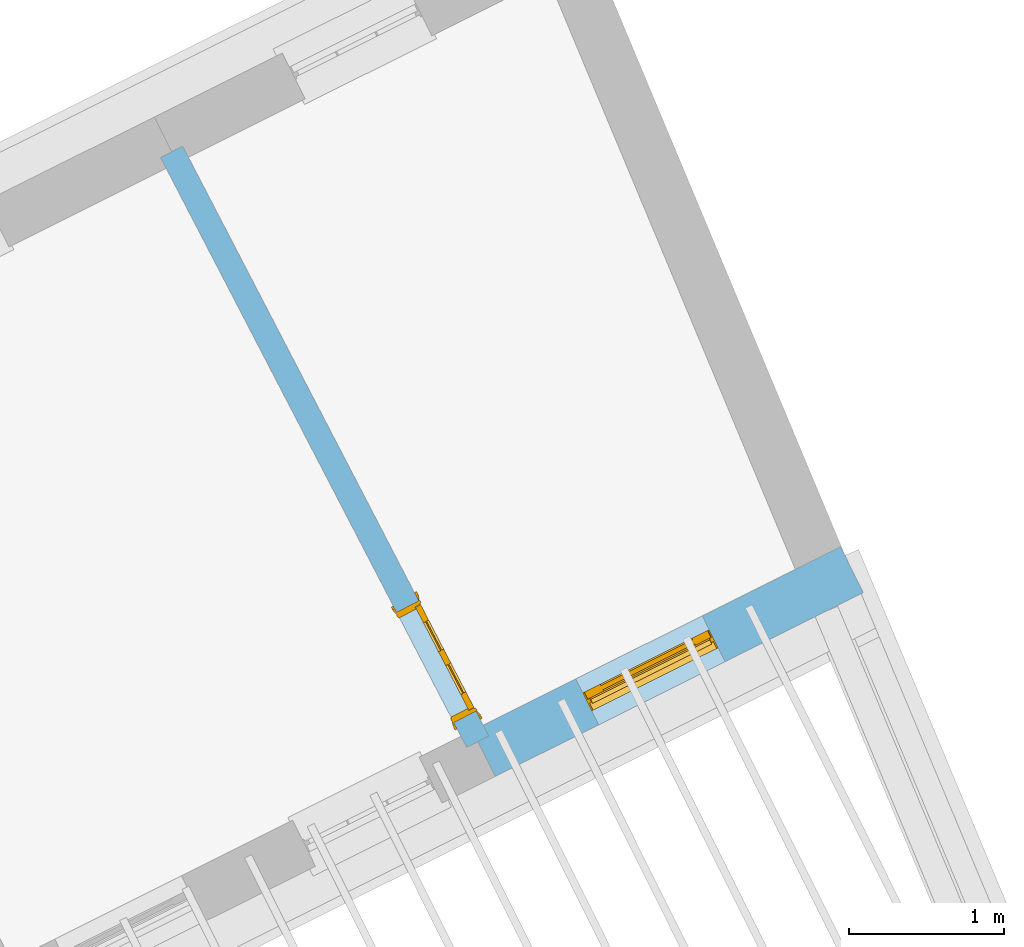
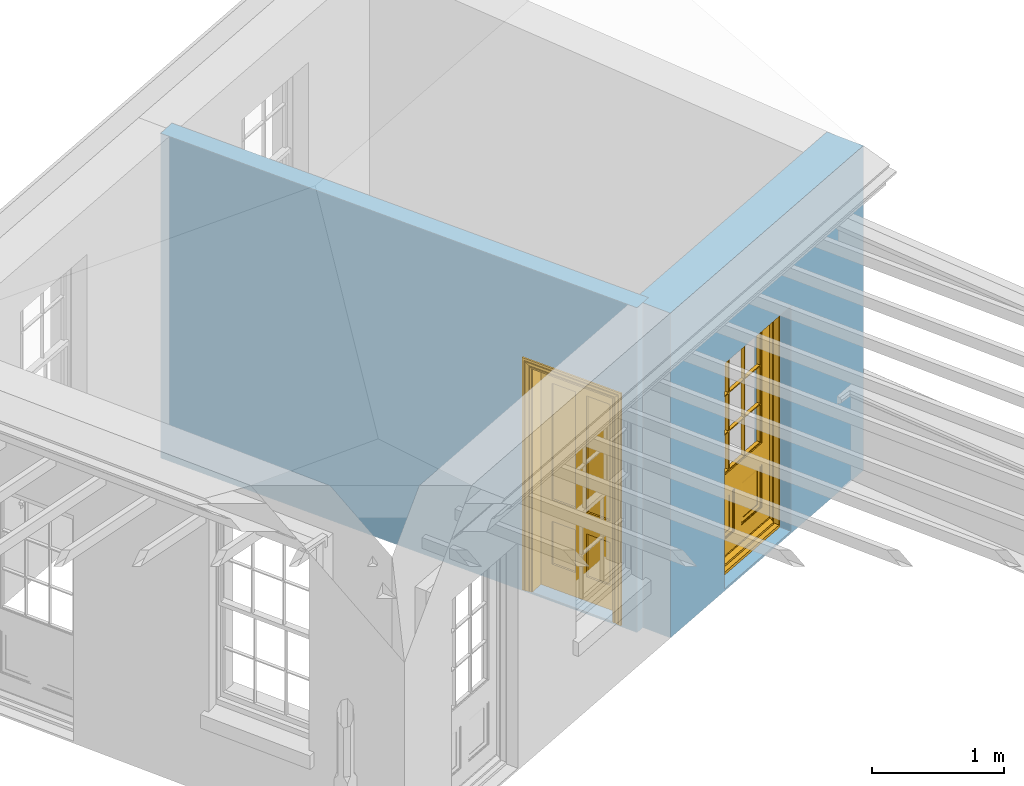
# One storey, part 4 of 7: 2 doors, 2 openings, plus 2 elements that do not belong to this part.
"""IFC2X3 building model written with IfcOpenShell, lengths in metres."""

from ifc_helpers import new_model, si_unit, frame, origin, place, context, subcontext, project, spatial, polyline, outline, extrude, faceted_brep, material, layer, layer_set, layer_usage, element, fill, save


model = new_model("IFC2X3")

# Units and contexts
model_context = context("Model", 3, world=origin())
body_context = subcontext(model_context, "Body", "Model", "MODEL_VIEW")
ifc_project = project(units=[si_unit("PLANEANGLEUNIT", "RADIAN"), si_unit("MASSUNIT", "GRAM", prefix="KILO"), si_unit("FORCEUNIT", "NEWTON", prefix="KILO"), si_unit("LENGTHUNIT", "METRE")], contexts=[model_context])

# Site, building, storey
site_placement = place(None, origin())
site = spatial("IfcSite", under=ifc_project, at=site_placement, CompositionType="ELEMENT")
building_placement = place(None, origin())
building = spatial("IfcBuilding", under=site, at=building_placement, Name="Building plot-8", CompositionType="ELEMENT")
storey_placement = place(None, frame((0.0, 0.0, 6.3)))
storey = spatial("IfcBuildingStorey", under=building, at=storey_placement, Name="Floor 2", CompositionType="ELEMENT", Elevation=6.3)

# Wall, opening, door
ifc_material_1 = material(Name="Masonry")
ifc_layer_1 = layer(ifc_material_1, 0.33, ventilated=False)
ifc_layer_set_1 = layer_set([ifc_layer_1], Name="My Wall")
ifc_layer_usage_1 = layer_usage(ifc_layer_set_1, "AXIS2", "NEGATIVE", 0.08)
wall_1_placement = place(storey_placement, origin())
wall_1 = element("IfcWallStandardCase", 1, at=wall_1_placement, inside=storey, material=ifc_layer_usage_1, Name="exterior", context=body_context, shape_type="SweptSolid", body=[
    extrude(outline(polyline([(27.4102456579562, 14.9420865634283), (27.5576474990724, 14.6468363352565), (29.9270645302191, 15.8297530595747), (29.7796626891029, 16.1250032877466), (27.4102456579562, 14.9420865634283)])), origin(), (0.0, 0.0, 1.0), 3.0),
])
opening_1_placement = place(storey_placement, frame((0.0, 0.0, 0.0199999999999996)))
opening_1 = element("IfcOpeningElement", 2, at=opening_1_placement, cuts=wall_1, Name="Opening", ObjectType="Opening", context=body_context, shape_type="SweptSolid", body=[
    extrude(outline(polyline([(28.2234313711922, 14.9792247948476), (29.0376062428176, 15.3856965385319), (28.8902044017014, 15.6809467667037), (28.0760295300759, 15.2744750230195), (28.2234313711922, 14.9792247948476)])), origin(), (0.0, 0.0, 1.0), 2.08),
])
door_1_placement = place(storey_placement, frame((28.1117633097405, 15.2028992101293, 0.0199999999999996), z_axis=(0.0, 0.0, 1.0), x_axis=(0.814174871625429, 0.406471743684248, 0.0)))
door_1 = element("IfcDoor", 3, at=door_1_placement, inside=storey, Name="bedroom outside door", OverallHeight=2.08, OverallWidth=0.91, context=body_context, shape_type="Brep", held_by="IfcProductRepresentation", body=[
    faceted_brep([(0.545, -0.055, 0.265), (0.745, -0.055, 0.265), (0.745, -0.05, 0.265), (0.545, -0.05, 0.265), (0.745, -0.05, 0.58), (0.545, -0.05, 0.58), (0.545, -0.055, 0.58), (0.515, -0.06, 0.235), (0.775, -0.06, 0.235), (0.745, -0.055, 0.58), (0.515, -0.06, 0.61), (0.515, -0.065, 0.235), (0.775, -0.065, 0.235), (0.775, -0.06, 0.61), (0.515, -0.065, 0.61), (0.785, -0.065, 0.225), (0.505, -0.065, 0.225), (0.775, -0.065, 0.61), (0.505, -0.065, 0.62), (0.785, -0.065, 0.62), (0.505, -0.07, 0.225), (0.785, -0.07, 0.225), (0.505, -0.07, 0.62), (0.785, -0.07, 0.62), (0.883, -0.07, 0.075), (0.898, -0.07, 0.075), (0.405, -0.07, 0.62), (0.405, -0.07, 0.225), (0.027, -0.07, 0.075), (0.785, -0.07, 0.82), (0.125, -0.07, 0.82), (0.405, -0.065, 0.62), (0.405, -0.065, 0.225), (0.898, -0.07, 2.068), (0.027, -0.08, 0.075), (0.883, -0.08, 0.075), (0.125, -0.07, 0.225), (0.012, -0.07, 0.075), (0.785, -0.06, 0.82), (0.125, -0.06, 0.82), (0.125, -0.07, 0.62), (0.125, -0.065, 0.62), (0.395, -0.065, 0.61), (0.395, -0.065, 0.235), (0.125, -0.065, 0.225), (0.785, -0.07, 1.895), (0.027, -0.11, 0.045), (0.883, -0.11, 0.045), (0.558333, -0.06, 0.83), (0.351667, -0.06, 0.83), (0.125, -0.07, 1.895), (0.125, -0.06, 1.895), (0.785, -0.06, 1.895), (0.012, -0.07, 2.068), (0.135, -0.065, 0.61), (0.395, -0.06, 0.61), (0.395, -0.06, 0.235), (0.135, -0.065, 0.235), (0.027, -0.11, 0.027), (0.883, -0.11, 0.027), (0.568333, -0.06, 0.83), (0.558333, -0.03, 0.83), (0.351667, -0.03, 0.83), (0.341667, -0.06, 0.83), (0.135, -0.06, 1.185), (0.135, -0.06, 1.53), (0.775, -0.06, 1.53), (0.775, -0.06, 1.185), (0.135, -0.06, 0.61), (0.365, -0.055, 0.58), (0.365, -0.055, 0.265), (0.135, -0.06, 0.235), (0.568333, -0.06, 1.175), (0.558333, -0.06, 1.175), (0.775, -0.06, 0.83), (0.558333, -0.03, 1.175), (0.785, -0.03, 0.82), (0.125, -0.03, 0.82), (0.351667, -0.03, 1.175), (0.351667, -0.06, 1.175), (0.341667, -0.06, 1.175), (0.135, -0.06, 0.83), (0.135, -0.06, 1.175), (0.135, -0.03, 1.185), (0.135, -0.03, 1.53), (0.135, -0.06, 1.54), (0.351667, -0.06, 1.885), (0.558333, -0.06, 1.885), (0.775, -0.03, 1.53), (0.775, -0.03, 1.185), (0.775, -0.06, 1.175), (0.775, -0.06, 1.54), (0.165, -0.055, 0.58), (0.365, -0.05, 0.58), (0.365, -0.05, 0.265), (0.165, -0.055, 0.265), (0.568333, -0.03, 0.83), (0.568333, -0.03, 1.175), (0.568333, -0.06, 1.185), (0.558333, -0.06, 1.185), (0.775, -0.03, 0.83), (0.785, -0.02, 0.82), (0.125, -0.02, 0.82), (0.341667, -0.03, 0.83), (0.341667, -0.03, 1.175), (0.351667, -0.06, 1.185), (0.341667, -0.06, 1.185), (0.135, -0.03, 0.83), (0.341667, -0.03, 1.185), (0.125, -0.03, 1.895), (0.341667, -0.03, 1.53), (0.341667, -0.06, 1.53), (0.135, -0.06, 1.885), (0.341667, -0.06, 1.54), (0.341667, -0.06, 1.885), (0.558333, -0.03, 1.885), (0.351667, -0.03, 1.885), (0.568333, -0.06, 1.885), (0.785, -0.03, 1.895), (0.568333, -0.03, 1.185), (0.568333, -0.06, 1.53), (0.568333, -0.03, 1.53), (0.568333, -0.06, 1.54), (0.775, -0.06, 1.885), (0.165, -0.05, 0.58), (0.165, -0.05, 0.265), (0.775, -0.03, 1.175), (0.558333, -0.06, 1.53), (0.351667, -0.03, 1.185), (0.558333, -0.03, 1.185), (0.505, -0.02, 0.62), (0.405, -0.02, 0.62), (0.125, -0.02, 1.895), (0.785, -0.02, 1.895), (0.351667, -0.06, 1.53), (0.135, -0.03, 1.175), (0.135, -0.03, 1.54), (0.341667, -0.03, 1.54), (0.135, -0.03, 1.885), (0.351667, -0.06, 1.54), (0.558333, -0.03, 1.54), (0.558333, -0.06, 1.54), (0.351667, -0.03, 1.54), (0.775, -0.03, 1.54), (0.568333, -0.03, 1.54), (0.775, -0.03, 1.885), (0.558333, -0.03, 1.53), (0.405, -0.02, 0.225), (0.505, -0.02, 0.225), (0.125, -0.02, 0.62), (0.785, -0.02, 0.62), (0.012, -0.02, 2.068), (0.898, -0.02, 2.068), (0.351667, -0.03, 1.53), (0.341667, -0.03, 1.885), (0.568333, -0.03, 1.885), (0.405, -0.025, 0.225), (0.405, -0.025, 0.62), (0.505, -0.025, 0.62), (0.505, -0.025, 0.225), (0.898, -0.02, 0.027), (0.012, -0.02, 0.027), (0.125, -0.025, 0.62), (0.785, -0.025, 0.62), (0.395, -0.025, 0.235), (0.395, -0.025, 0.61), (0.125, -0.02, 0.225), (0.125, -0.025, 0.225), (0.515, -0.025, 0.61), (0.515, -0.025, 0.235), (0.785, -0.02, 0.225), (0.785, -0.025, 0.225), (0.135, -0.025, 0.61), (0.775, -0.025, 0.61), (0.135, -0.025, 0.235), (0.395, -0.03, 0.235), (0.395, -0.03, 0.61), (0.515, -0.03, 0.61), (0.515, -0.03, 0.235), (0.775, -0.025, 0.235), (0.135, -0.03, 0.61), (0.775, -0.03, 0.61), (0.135, -0.03, 0.235), (0.365, -0.035, 0.265), (0.365, -0.035, 0.58), (0.545, -0.035, 0.58), (0.545, -0.035, 0.265), (0.775, -0.03, 0.235), (0.165, -0.035, 0.58), (0.745, -0.035, 0.58), (0.165, -0.035, 0.265), (0.365, -0.04, 0.58), (0.365, -0.04, 0.265), (0.545, -0.04, 0.58), (0.545, -0.04, 0.265), (0.745, -0.035, 0.265), (0.165, -0.04, 0.58), (0.745, -0.04, 0.58), (0.165, -0.04, 0.265), (0.745, -0.04, 0.265), (0.885, -0.072, 0.025), (0.025, -0.072, 0.025), (0.025, -0.1, 0.025), (0.885, -0.1, 0.025), (0.9, -0.02, 0.025), (0.01, -0.02, 0.025), (0.9, -0.072, 0.025), (0.91, -0.02, 0.0), (0.0, -0.02, 0.0), (0.01, -0.072, 0.025), (0.9, -0.072, 2.07), (0.9, -0.02, 2.07), (0.885, -0.072, 2.055), (0.91, -0.02, 2.08), (0.01, -0.02, 2.07), (0.0, -0.02, 2.08), (0.01, -0.072, 2.07), (0.025, -0.072, 2.055), (0.0, -0.15, 2.08), (0.91, -0.15, 2.08), (0.01, -0.15, 2.07), (0.9, -0.15, 2.07), (0.01, -0.1, 2.07), (0.9, -0.1, 2.07), (0.0, -0.15, 0.0), (0.91, -0.15, 0.0), (0.01, -0.15, 0.025), (0.9, -0.15, 0.025), (0.01, -0.1, 0.025), (0.025, -0.1, 2.055), (0.9, -0.1, 0.025), (0.885, -0.1, 2.055), (0.898, -0.07, 0.027), (0.012, -0.07, 0.027), (0.883, -0.07, 0.027), (0.027, -0.07, 0.027)], [[[0, 1, 2, 3]], [[2, 4, 5, 3]], [[0, 3, 5, 6]], [[1, 0, 7, 8]], [[9, 4, 2, 1]], [[9, 6, 5, 4]], [[0, 6, 10, 7]], [[8, 7, 11, 12]], [[8, 13, 9, 1]], [[13, 10, 6, 9]], [[7, 10, 14, 11]], [[15, 12, 11, 16]], [[12, 17, 13, 8]], [[17, 14, 10, 13]], [[18, 16, 11, 14]], [[15, 19, 17, 12]], [[15, 16, 20, 21]], [[14, 17, 19, 18]], [[16, 18, 22, 20]], [[21, 23, 19, 15]], [[24, 25, 21, 20]], [[23, 22, 18, 19]], [[20, 22, 26, 27]], [[23, 21, 25]], [[28, 24, 20, 27]], [[22, 23, 29]], [[29, 30, 26, 22]], [[27, 26, 31, 32]], [[23, 25, 33, 29]], [[34, 35, 24, 28]], [[28, 27, 36, 37]], [[38, 39, 30, 29]], [[26, 30, 40]], [[26, 40, 41, 31]], [[42, 43, 32, 31]], [[32, 44, 36, 27]], [[33, 45, 29]], [[46, 47, 35, 34]], [[36, 40, 37]], [[39, 38, 48, 49]], [[50, 30, 39, 51]], [[29, 45, 52, 38]], [[53, 37, 40, 30]], [[44, 41, 40, 36]], [[31, 41, 54, 42]], [[43, 42, 55, 56]], [[57, 44, 32, 43]], [[50, 45, 33, 53]], [[47, 46, 58, 59]], [[60, 48, 38]], [[49, 48, 61, 62]], [[49, 63, 39]], [[50, 53, 30]], [[51, 39, 64, 65]], [[45, 50, 51, 52]], [[66, 67, 38, 52]], [[57, 54, 41, 44]], [[42, 54, 68, 55]], [[56, 55, 69, 70]], [[56, 71, 57, 43]], [[60, 72, 73, 48]], [[60, 38, 74]], [[48, 73, 75, 61]], [[76, 77, 62, 61]], [[62, 78, 79, 49]], [[49, 79, 80, 63]], [[63, 81, 39]], [[82, 64, 39]], [[65, 64, 83, 84]], [[85, 51, 65]], [[52, 51, 86, 87]], [[88, 89, 67, 66]], [[90, 38, 67]], [[91, 66, 52]], [[71, 68, 54, 57]], [[55, 68, 92, 69]], [[69, 93, 94, 70]], [[70, 95, 71, 56]], [[96, 97, 72, 60]], [[73, 72, 98, 99]], [[74, 38, 90]], [[100, 96, 60, 74]], [[75, 73, 79, 78]], [[61, 75, 97, 96]], [[101, 102, 77, 76]], [[77, 103, 62]], [[96, 76, 61]], [[103, 104, 78, 62]], [[80, 79, 105, 106]], [[63, 80, 104, 103]], [[81, 63, 103, 107]], [[81, 82, 39]], [[106, 64, 82, 80]], [[106, 108, 83, 64]], [[84, 83, 77, 109]], [[110, 111, 65, 84]], [[112, 51, 85]], [[113, 85, 65, 111]], [[114, 86, 51]], [[115, 87, 86, 116]], [[117, 52, 87]], [[118, 76, 89, 88]], [[119, 98, 67, 89]], [[120, 121, 88, 66]], [[67, 98, 72, 90]], [[91, 122, 120, 66]], [[91, 52, 123]], [[95, 92, 68, 71]], [[69, 92, 124, 93]], [[94, 93, 124, 125]], [[94, 125, 95, 70]], [[72, 97, 126, 90]], [[127, 99, 98, 120]], [[99, 105, 79, 73]], [[74, 90, 126, 100]], [[96, 100, 76]], [[128, 129, 75, 78]], [[97, 75, 129, 119]], [[130, 131, 102, 101]], [[109, 77, 102, 132]], [[133, 101, 76, 118]], [[77, 107, 103]], [[78, 104, 108, 128]], [[111, 106, 105, 134]], [[104, 80, 82, 135]], [[107, 135, 82, 81]], [[110, 108, 106, 111]], [[104, 135, 83, 108]], [[83, 135, 77]], [[136, 84, 109]], [[110, 84, 136, 137]], [[114, 51, 112]], [[85, 136, 138, 112]], [[113, 137, 136, 85]], [[111, 134, 139, 113]], [[86, 114, 113, 139]], [[140, 141, 87, 115]], [[139, 142, 116, 86]], [[109, 118, 115, 116]], [[117, 123, 52]], [[117, 87, 141, 122]], [[126, 89, 76]], [[143, 118, 88]], [[120, 98, 119, 121]], [[119, 89, 126, 97]], [[144, 143, 88, 121]], [[144, 122, 91, 143]], [[127, 120, 122, 141]], [[143, 91, 123, 145]], [[124, 92, 95, 125]], [[146, 129, 99, 127]], [[99, 129, 128, 105]], [[100, 126, 76]], [[121, 119, 129, 146]], [[147, 131, 130, 148]], [[131, 149, 102]], [[130, 101, 150]], [[102, 151, 132]], [[118, 109, 132, 133]], [[101, 133, 152]], [[107, 77, 135]], [[153, 128, 108, 110]], [[134, 105, 128, 153]], [[109, 138, 136]], [[153, 110, 137, 142]], [[154, 114, 112, 138]], [[137, 113, 114, 154]], [[141, 139, 134, 127]], [[141, 140, 142, 139]], [[144, 140, 115, 155]], [[142, 137, 154, 116]], [[155, 115, 118]], [[116, 154, 109]], [[117, 155, 145, 123]], [[122, 144, 155, 117]], [[143, 145, 118]], [[121, 146, 140, 144]], [[146, 127, 134, 153]], [[156, 157, 131, 147]], [[148, 130, 158, 159]], [[148, 160, 161, 147]], [[157, 162, 149, 131]], [[161, 151, 102, 149]], [[101, 152, 160, 150]], [[163, 158, 130, 150]], [[151, 152, 133, 132]], [[154, 138, 109]], [[142, 140, 146, 153]], [[145, 155, 118]], [[157, 156, 164, 165]], [[147, 166, 167, 156]], [[168, 169, 159, 158]], [[170, 148, 159, 171]], [[148, 170, 160]], [[166, 147, 161]], [[172, 162, 157, 165]], [[166, 149, 162, 167]], [[166, 161, 149]], [[150, 160, 170]], [[163, 173, 168, 158]], [[171, 163, 150, 170]], [[174, 164, 156, 167]], [[175, 176, 165, 164]], [[169, 168, 177, 178]], [[171, 159, 169, 179]], [[167, 162, 172, 174]], [[176, 180, 172, 165]], [[179, 173, 163, 171]], [[181, 177, 168, 173]], [[164, 174, 182, 175]], [[183, 184, 176, 175]], [[178, 177, 185, 186]], [[179, 169, 178, 187]], [[174, 172, 180, 182]], [[184, 188, 180, 176]], [[187, 181, 173, 179]], [[189, 185, 177, 181]], [[175, 182, 190, 183]], [[191, 184, 183, 192]], [[185, 193, 194, 186]], [[187, 178, 186, 195]], [[182, 180, 188, 190]], [[191, 196, 188, 184]], [[195, 189, 181, 187]], [[197, 193, 185, 189]], [[183, 190, 198, 192]], [[198, 196, 191, 192]], [[194, 193, 197, 199]], [[195, 186, 194, 199]], [[188, 196, 198, 190]], [[197, 189, 195, 199]], [[200, 201, 202, 203]], [[201, 200, 204, 205]], [[206, 204, 200]], [[204, 207, 208, 205]], [[209, 201, 205]], [[210, 211, 204, 206]], [[206, 200, 212, 210]], [[211, 213, 207, 204]], [[214, 205, 208, 215]], [[216, 217, 201, 209]], [[205, 214, 216, 209]], [[216, 214, 211, 210]], [[210, 212, 217, 216]], [[214, 215, 213, 211]], [[218, 219, 213, 215]], [[219, 218, 220, 221]], [[221, 220, 222, 223]], [[215, 208, 224, 218]], [[225, 224, 208, 207]], [[224, 226, 220, 218]], [[224, 225, 227, 226]], [[219, 225, 207, 213]], [[228, 222, 220, 226]], [[219, 221, 227, 225]], [[226, 227, 203, 202]], [[202, 229, 222, 228]], [[228, 226, 202]], [[227, 221, 223, 230]], [[230, 203, 227]], [[217, 229, 202, 201]], [[231, 223, 222, 229]], [[230, 223, 231, 203]], [[231, 229, 217, 212]], [[212, 200, 203, 231]], [[33, 152, 151, 53]], [[25, 160, 152, 33]], [[161, 37, 53, 151]], [[232, 160, 25]], [[161, 233, 37]], [[160, 232, 234]], [[24, 234, 232, 25]], [[233, 161, 235]], [[37, 233, 235, 28]], [[161, 160, 234, 235]], [[35, 47, 234, 24]], [[28, 235, 46, 34]], [[58, 235, 234, 59]], [[59, 234, 47]], [[58, 46, 235]]]),
])
fill(opening_1, door_1)

ifc_material_2 = material(Name="Masonry")
ifc_layer_2 = layer(ifc_material_2, 0.16, ventilated=False)
ifc_layer_set_2 = layer_set([ifc_layer_2], Name="My Wall")
ifc_layer_usage_2 = layer_usage(ifc_layer_set_2, "AXIS2", "NEGATIVE", 0.08)
wall_2_placement = place(storey_placement, origin())
wall_2 = element("IfcWallStandardCase", 4, at=wall_2_placement, inside=storey, material=ifc_layer_usage_2, Name="interior", context=body_context, shape_type="SweptSolid", body=[
    extrude(outline(polyline([(25.5470428086069, 18.7028747535873), (25.4050311441155, 18.6291679889833), (27.374973605375, 14.8336573682362), (27.5169852698664, 14.9073641328402), (25.5470428086069, 18.7028747535873)])), origin(), (0.0, 0.0, 1.0), 3.0),
])
opening_2_placement = place(storey_placement, frame((0.0, 0.0, 0.0199999999999996)))
opening_2 = element("IfcOpeningElement", 5, at=opening_2_placement, cuts=wall_2, Name="Opening", ObjectType="Opening", context=body_context, shape_type="SweptSolid", body=[
    extrude(outline(polyline([(26.9235196721751, 15.7034788132456), (27.2920534951955, 14.9934204907889), (27.4340651596868, 15.067127255393), (27.0655313366665, 15.7771855778497), (26.9235196721751, 15.7034788132456)])), origin(), (0.0, 0.0, 1.0), 2.1),
])
door_2_placement = place(storey_placement, frame((26.9945255044208, 15.7403321955477, 0.0199999999999996), z_axis=(0.0, 0.0, 1.0), x_axis=(0.368533823020318, -0.710058322456703, 0.0)))
door_2 = element("IfcDoor", 6, at=door_2_placement, inside=storey, Name="bedroom inside door", OverallHeight=2.1, OverallWidth=0.8, context=body_context, shape_type="Brep", held_by="IfcProductRepresentation", body=[
    faceted_brep([(0.773, 0.08, 1.895), (0.66, 0.08, 1.895), (0.66, 0.08, 2.073), (0.773, 0.08, 2.073), (0.773, 0.08, 0.82), (0.66, 0.08, 0.82), (0.45, 0.08, 1.895), (0.45, 0.08, 2.073), (0.773, 0.08, 0.62), (0.66, 0.08, 0.62), (0.66, 0.065, 0.82), (0.66, 0.065, 1.895), (0.45, 0.065, 1.895), (0.35, 0.08, 1.895), (0.35, 0.08, 2.073), (0.773, 0.08, 0.225), (0.66, 0.08, 0.225), (0.45, 0.08, 0.62), (0.45, 0.08, 0.82), (0.45, 0.065, 0.82), (0.35, 0.08, 0.82), (0.14, 0.08, 2.073), (0.14, 0.08, 1.895), (0.773, 0.08, 0.0), (0.66, 0.08, 0.0), (0.66, 0.065, 0.225), (0.66, 0.065, 0.62), (0.45, 0.065, 0.62), (0.35, 0.08, 0.62), (0.35, 0.065, 0.82), (0.35, 0.065, 1.895), (0.14, 0.065, 1.895), (0.027, 0.08, 2.073), (0.027, 0.08, 1.895), (0.773, 0.042, 0.0), (0.66, 0.042, 0.0), (0.45, 0.08, 0.0), (0.45, 0.08, 0.225), (0.45, 0.065, 0.225), (0.35, 0.08, 0.225), (0.14, 0.08, 0.82), (0.14, 0.08, 0.62), (0.14, 0.065, 0.82), (0.027, 0.08, 0.82), (0.773, 0.042, 0.225), (0.66, 0.042, 0.225), (0.45, 0.042, 0.0), (0.35, 0.08, 0.0), (0.35, 0.065, 0.225), (0.35, 0.065, 0.62), (0.14, 0.065, 0.62), (0.027, 0.08, 0.62), (0.773, 0.042, 0.62), (0.66, 0.042, 0.62), (0.45, 0.042, 0.225), (0.35, 0.042, 0.0), (0.14, 0.08, 0.225), (0.14, 0.08, 0.0), (0.14, 0.065, 0.225), (0.027, 0.08, 0.225), (0.773, 0.042, 0.82), (0.66, 0.042, 0.82), (0.66, 0.057, 0.62), (0.66, 0.057, 0.225), (0.45, 0.057, 0.225), (0.35, 0.042, 0.225), (0.14, 0.042, 0.0), (0.027, 0.08, 0.0), (0.773, 0.042, 1.895), (0.66, 0.042, 1.895), (0.45, 0.042, 0.62), (0.45, 0.042, 0.82), (0.45, 0.057, 0.62), (0.35, 0.042, 0.62), (0.14, 0.042, 0.225), (0.027, 0.042, 0.0), (0.773, 0.042, 2.073), (0.66, 0.042, 2.073), (0.66, 0.057, 1.895), (0.66, 0.057, 0.82), (0.45, 0.057, 0.82), (0.35, 0.042, 0.82), (0.35, 0.057, 0.62), (0.35, 0.057, 0.225), (0.14, 0.057, 0.225), (0.027, 0.042, 0.225), (0.45, 0.042, 1.895), (0.45, 0.042, 2.073), (0.45, 0.057, 1.895), (0.35, 0.042, 1.895), (0.14, 0.042, 0.82), (0.14, 0.042, 0.62), (0.14, 0.057, 0.62), (0.027, 0.042, 0.62), (0.35, 0.042, 2.073), (0.35, 0.057, 1.895), (0.35, 0.057, 0.82), (0.14, 0.057, 0.82), (0.027, 0.042, 0.82), (0.14, 0.042, 2.073), (0.14, 0.042, 1.895), (0.14, 0.057, 1.895), (0.027, 0.042, 1.895), (0.027, 0.042, 2.073), (0.02, 0.085, 0.0), (0.005, 0.09, 0.0), (0.005, 0.09, 2.095), (0.02, 0.085, 2.08), (0.02, 0.08, 0.0), (0.0, 0.085, 0.0), (0.0, 0.085, 2.1), (0.795, 0.09, 2.095), (0.78, 0.085, 2.08), (0.02, 0.08, 2.08), (0.0, 0.08, 0.0), (-0.032, 0.095, 0.0), (-0.032, 0.095, 2.132), (0.8, 0.085, 2.1), (0.795, 0.09, 0.0), (0.78, 0.085, 0.0), (0.78, 0.08, 2.08), (0.04, 0.04, 0.0), (0.025, 0.04, 0.0), (0.025, 0.04, 2.075), (0.04, 0.04, 2.06), (-0.04, 0.09, 0.0), (-0.04, 0.09, 2.14), (0.832, 0.095, 2.132), (0.8, 0.085, 0.0), (0.78, 0.08, 0.0), (0.8, 0.08, 0.0), (0.86, 0.08, 0.0), (0.86, 0.08, 2.16), (0.8, 0.08, 2.1), (-0.06, 0.08, 2.16), (0.0, 0.08, 2.1), (-0.06, 0.08, 0.0), (-0.04, 0.095, 0.0), (-0.04, 0.095, 2.14), (0.84, 0.09, 2.14), (0.832, 0.095, 0.0), (0.84, 0.09, 0.0), (0.86, 0.095, 0.0), (0.86, 0.095, 2.16), (-0.06, 0.095, 2.16), (-0.06, 0.095, 0.0), (0.84, 0.095, 0.0), (0.84, 0.095, 2.14), (-0.025, -0.095, 0.0), (-0.025, -0.09, 0.0), (-0.025, -0.09, 2.125), (-0.025, -0.095, 2.125), (-0.017, -0.095, 0.0), (-0.017, -0.095, 2.117), (0.825, -0.09, 2.125), (0.825, -0.095, 2.125), (0.825, -0.095, 0.0), (0.845, -0.095, 0.0), (-0.045, -0.095, 2.145), (-0.045, -0.095, 0.0), (0.845, -0.095, 2.145), (0.015, -0.085, 0.0), (0.015, -0.085, 2.085), (0.817, -0.095, 2.117), (0.825, -0.09, 0.0), (0.845, -0.08, 0.0), (0.845, -0.08, 2.145), (-0.045, -0.08, 2.145), (-0.045, -0.08, 0.0), (0.02, -0.09, 0.0), (0.02, -0.09, 2.08), (0.785, -0.085, 2.085), (0.817, -0.095, 0.0), (0.8, -0.08, 0.0), (0.8, -0.08, 2.1), (0.0, -0.08, 2.1), (0.0, -0.08, 0.0), (0.035, -0.085, 0.0), (0.035, -0.085, 2.065), (0.78, -0.09, 2.08), (0.785, -0.085, 0.0), (0.775, 0.04, 2.075), (0.76, 0.04, 2.06), (0.035, -0.08, 2.065), (0.035, -0.08, 0.0), (0.765, -0.085, 2.065), (0.78, -0.09, 0.0), (0.765, -0.08, 0.0), (0.765, -0.08, 2.065), (0.765, -0.085, 0.0), (0.04, -0.08, 2.06), (0.04, -0.08, 0.0), (0.76, -0.08, 2.06), (0.76, -0.08, 0.0), (0.76, 0.04, 0.0), (0.775, 0.04, 0.0), (0.025, 0.08, 0.0), (0.025, 0.08, 2.075), (0.775, 0.08, 0.0), (0.775, 0.08, 2.075)], [[[0, 1, 2, 3]], [[1, 0, 4, 5]], [[1, 6, 7, 2]], [[8, 9, 5, 4]], [[1, 5, 10, 11]], [[6, 1, 11, 12]], [[6, 13, 14, 7]], [[15, 16, 9, 8]], [[9, 17, 18, 5]], [[5, 18, 19, 10]], [[10, 19, 12, 11]], [[18, 6, 12, 19]], [[18, 20, 13, 6]], [[21, 14, 13, 22]], [[23, 24, 16, 15]], [[9, 16, 25, 26]], [[17, 9, 26, 27]], [[17, 28, 20, 18]], [[13, 20, 29, 30]], [[22, 13, 30, 31]], [[32, 21, 22, 33]], [[34, 35, 24, 23]], [[24, 36, 37, 16]], [[16, 37, 38, 25]], [[25, 38, 27, 26]], [[37, 17, 27, 38]], [[37, 39, 28, 17]], [[40, 20, 28, 41]], [[20, 40, 42, 29]], [[31, 30, 29, 42]], [[40, 22, 31, 42]], [[33, 22, 40, 43]], [[35, 34, 44, 45]], [[35, 46, 36, 24]], [[36, 47, 39, 37]], [[28, 39, 48, 49]], [[41, 28, 49, 50]], [[43, 40, 41, 51]], [[45, 44, 52, 53]], [[46, 35, 45, 54]], [[46, 55, 47, 36]], [[56, 39, 47, 57]], [[39, 56, 58, 48]], [[50, 49, 48, 58]], [[56, 41, 50, 58]], [[51, 41, 56, 59]], [[53, 52, 60, 61]], [[45, 53, 62, 63]], [[54, 45, 63, 64]], [[55, 46, 54, 65]], [[55, 66, 57, 47]], [[59, 56, 57, 67]], [[61, 60, 68, 69]], [[70, 53, 61, 71]], [[53, 70, 72, 62]], [[72, 64, 63, 62]], [[70, 54, 64, 72]], [[65, 54, 70, 73]], [[65, 74, 66, 55]], [[67, 57, 66, 75]], [[69, 68, 76, 77]], [[61, 69, 78, 79]], [[71, 61, 79, 80]], [[73, 70, 71, 81]], [[65, 73, 82, 83]], [[74, 65, 83, 84]], [[74, 85, 75, 66]], [[86, 69, 77, 87]], [[69, 86, 88, 78]], [[88, 80, 79, 78]], [[86, 71, 80, 88]], [[81, 71, 86, 89]], [[73, 81, 90, 91]], [[73, 91, 92, 82]], [[83, 82, 92, 84]], [[91, 74, 84, 92]], [[91, 93, 85, 74]], [[89, 86, 87, 94]], [[81, 89, 95, 96]], [[90, 81, 96, 97]], [[90, 98, 93, 91]], [[94, 99, 100, 89]], [[89, 100, 101, 95]], [[101, 97, 96, 95]], [[100, 90, 97, 101]], [[100, 102, 98, 90]], [[99, 103, 102, 100]], [[32, 103, 99, 21]], [[102, 103, 32, 33]], [[98, 102, 33, 43]], [[21, 99, 94, 14]], [[94, 87, 7, 14]], [[7, 87, 77, 2]], [[76, 3, 2, 77]], [[43, 51, 93, 98]], [[51, 59, 85, 93]], [[67, 75, 85, 59]], [[34, 23, 15, 44]], [[44, 15, 8, 52]], [[52, 8, 4, 60]], [[0, 68, 60, 4]], [[0, 3, 76, 68]], [[104, 105, 106, 107]], [[104, 108, 109, 105]], [[105, 109, 110, 106]], [[107, 106, 111, 112]], [[107, 113, 108, 104]], [[114, 109, 108]], [[109, 115, 116, 110]], [[106, 110, 117, 111]], [[112, 111, 118, 119]], [[113, 107, 112, 120]], [[121, 122, 123, 124]], [[115, 109, 114, 125]], [[115, 125, 126, 116]], [[110, 116, 127, 117]], [[111, 117, 128, 118]], [[118, 128, 129, 119]], [[120, 112, 119, 129]], [[130, 129, 128]], [[130, 131, 132, 133]], [[133, 132, 134, 135]], [[135, 134, 136, 114]], [[136, 125, 114]], [[125, 137, 138, 126]], [[116, 126, 139, 127]], [[117, 127, 140, 128]], [[141, 130, 128, 140]], [[131, 130, 141]], [[131, 142, 143, 132]], [[132, 143, 144, 134]], [[134, 144, 145, 136]], [[137, 125, 136, 145]], [[143, 142, 146]], [[143, 146, 147]], [[137, 145, 144]], [[143, 147, 138]], [[138, 137, 144]], [[143, 138, 144]], [[126, 138, 147, 139]], [[127, 139, 141, 140]], [[142, 131, 141, 146]], [[139, 147, 146, 141]], [[148, 149, 150, 151]], [[149, 152, 153, 150]], [[151, 150, 154, 155]], [[155, 156, 157]], [[158, 159, 148]], [[158, 148, 151]], [[155, 157, 160]], [[158, 151, 155]], [[155, 160, 158]], [[152, 161, 162, 153]], [[150, 153, 163, 154]], [[155, 154, 164, 156]], [[156, 164, 165, 157]], [[157, 165, 166, 160]], [[160, 166, 167, 158]], [[158, 167, 168, 159]], [[161, 169, 170, 162]], [[153, 162, 171, 163]], [[154, 163, 172, 164]], [[165, 164, 173]], [[165, 173, 174, 166]], [[166, 174, 175, 167]], [[167, 175, 176, 168]], [[169, 177, 178, 170]], [[162, 170, 179, 171]], [[163, 171, 180, 172]], [[172, 180, 173, 164]], [[124, 123, 181, 182]], [[183, 178, 177, 184]], [[170, 178, 185, 179]], [[171, 179, 186, 180]], [[187, 173, 180]], [[185, 188, 187, 189]], [[188, 185, 178, 183]], [[179, 185, 189, 186]], [[189, 187, 180, 186]], [[190, 183, 184, 191]], [[192, 188, 183, 190]], [[191, 184, 122, 121]], [[124, 190, 191, 121]], [[193, 187, 188, 192]], [[182, 192, 190, 124]], [[184, 176, 122]], [[194, 195, 187, 193]], [[192, 182, 194, 193]], [[161, 176, 184]], [[114, 108, 122, 176]], [[173, 187, 195]], [[152, 149, 176, 161]], [[169, 161, 184, 177]], [[196, 122, 108]], [[176, 175, 135, 114]], [[173, 195, 129, 130]], [[176, 149, 168]], [[123, 122, 196, 197]], [[196, 108, 113, 197]], [[175, 174, 133, 135]], [[198, 129, 195]], [[133, 174, 173, 130]], [[159, 168, 149, 148]], [[181, 123, 197, 199]], [[197, 113, 120, 199]], [[199, 120, 129, 198]], [[195, 181, 199, 198]], [[195, 194, 182, 181]]]),
])
fill(opening_2, door_2)

save(model, "model.ifc")
